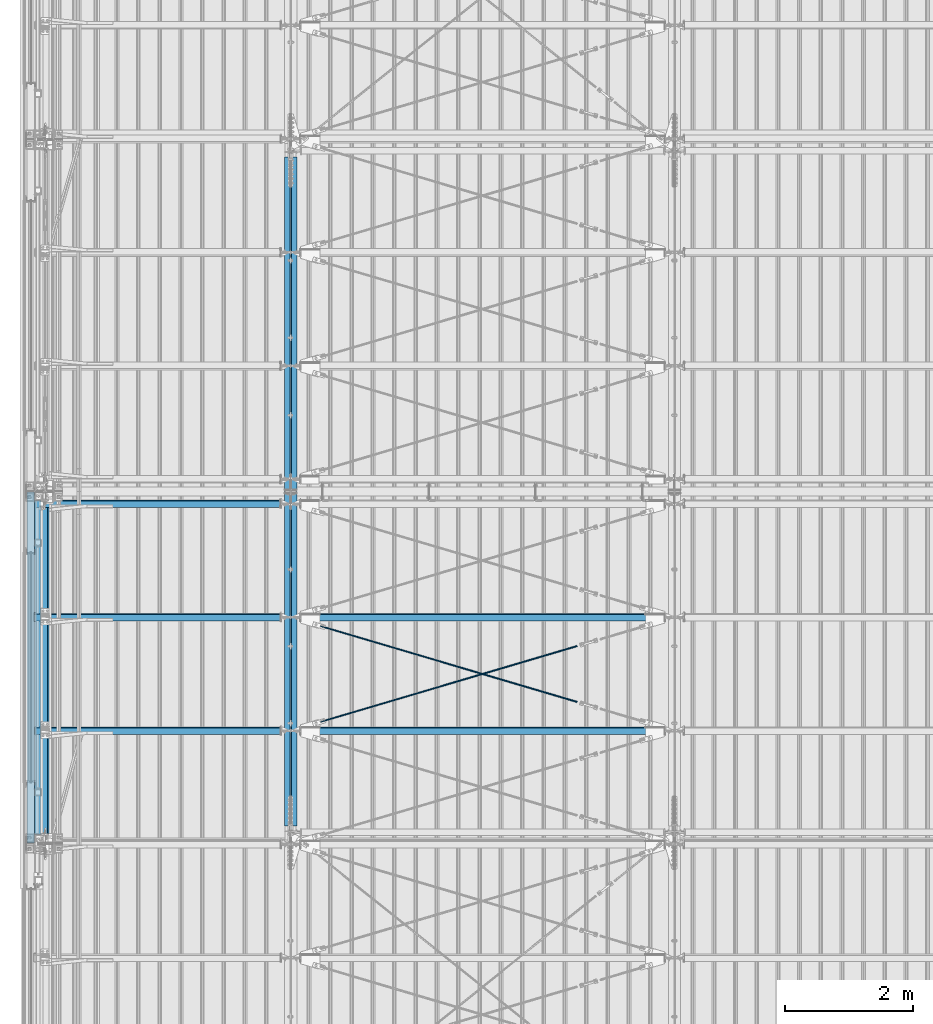
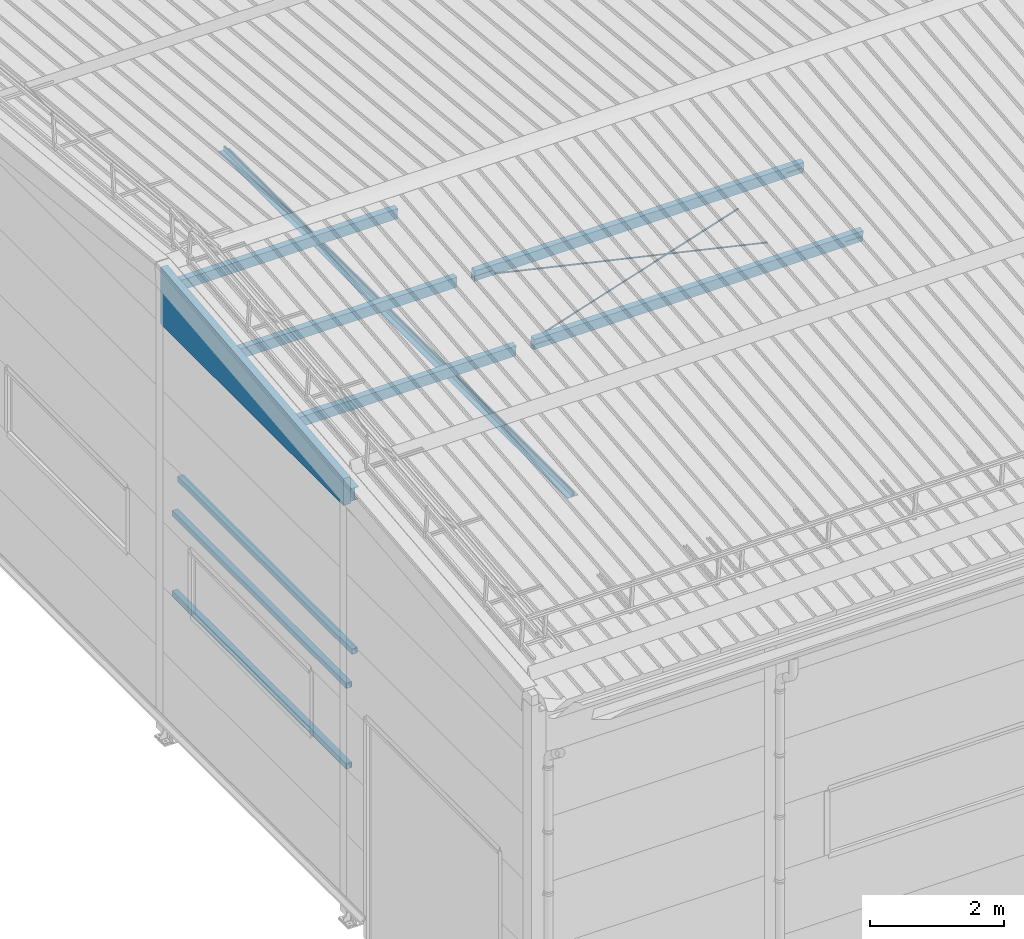
# One storey, part 245 of 709: 14 beams, 6 openings, 14 elements without a shape of their own.
"""IFC4 building model written with IfcOpenShell, lengths in millimetres."""

from ifc_helpers import new_model, si_unit, direction, frame, origin_with_axes, place, context, subcontext, project, spatial, line, indexed_curve, outline, extrude, polygons, material, element, aggregate, save


model = new_model("IFC4")

# Units and contexts
model_context = context("Model", 3, precision=0.2, world=origin_with_axes(), true_north=direction((0.0, 1.0)))
body_context = subcontext(model_context, "Body", "Model", "MODEL_VIEW")
reference_context = subcontext(model_context, "Reference", "Model", "MODEL_VIEW")
ifc_project = project(units=[si_unit("LENGTHUNIT", "METRE", prefix="MILLI"), si_unit("AREAUNIT", "SQUARE_METRE"), si_unit("VOLUMEUNIT", "CUBIC_METRE"), si_unit("MASSUNIT", "GRAM", prefix="KILO"), si_unit("TIMEUNIT", "SECOND"), si_unit("PLANEANGLEUNIT", "RADIAN"), si_unit("SOLIDANGLEUNIT", "STERADIAN"), si_unit("THERMODYNAMICTEMPERATUREUNIT", "DEGREE_CELSIUS"), si_unit("LUMINOUSINTENSITYUNIT", "LUMEN")], contexts=[model_context])

# Site, building, storey
site_placement = place(None, origin_with_axes())
site = spatial("IfcSite", under=ifc_project, at=site_placement, CompositionType="ELEMENT")
building_placement = place(site_placement, origin_with_axes())
building = spatial("IfcBuilding", under=site, at=building_placement, Name="Undefined", CompositionType="ELEMENT")
storey_placement = place(building_placement, origin_with_axes())
storey = spatial("IfcBuildingStorey", under=building, at=storey_placement, Name="Undefined", CompositionType="ELEMENT", Elevation=0.0)

# Assembly, beam
assembly_1_placement = place(storey_placement, frame((3949.0, 5673.0, 6045.00002), z_axis=(0.0, 0.0, 1.0), x_axis=(0.0, 1.0, 0.0)))
assembly_1 = element("IfcElementAssembly", 1, at=assembly_1_placement, inside=storey)
ifc_material_1 = material(Name="C345-5", Category="STEEL")
beam_1_placement = place(assembly_1_placement, origin_with_axes())
beam_1 = element("IfcBeam", 2, at=beam_1_placement, material=ifc_material_1, ObjectType="433", context=body_context, shape_type="Tessellation", body=[
    polygons([(100.0, -45.0, -45.0), (100.0, 45.0, -45.0), (10554.0, 45.0, -45.0), (10554.0, -45.0, -45.0), (100.0, 45.0, -39.0), (10554.0, 45.0, -39.0), (100.0, -39.0, -39.0), (10554.0, -39.0, -39.0), (100.0, -39.0, 45.0), (10554.0, -39.0, 45.0), (100.0, -45.0, 45.0), (10554.0, -45.0, 45.0)], [[[1, 2, 3, 4]], [[2, 5, 6, 3]], [[5, 7, 8, 6]], [[7, 9, 10, 8]], [[9, 11, 12, 10]], [[11, 1, 4, 12]], [[6, 8, 10, 12, 4, 3]], [[11, 9, 7, 5, 2, 1]]], closed=True),
])
aggregate(assembly_1, [beam_1])

assembly_2_placement = place(storey_placement, frame((4051.0, 16327.0, 6045.00002), z_axis=(0.0, 0.0, 1.0), x_axis=(0.0, -1.0, 0.0)))
assembly_2 = element("IfcElementAssembly", 3, at=assembly_2_placement, inside=storey)
beam_2_placement = place(assembly_2_placement, origin_with_axes())
beam_2 = element("IfcBeam", 4, at=beam_2_placement, material=ifc_material_1, ObjectType="434", context=body_context, shape_type="Tessellation", body=[
    polygons([(100.0, -45.0, -45.0), (100.0, 45.0, -45.0), (10554.0, 45.0, -45.0), (10554.0, -45.0, -45.0), (100.0, 45.0, -39.0), (10554.0, 45.0, -39.0), (100.0, -39.0, -39.0), (10554.0, -39.0, -39.0), (100.0, -39.0, 45.0), (10554.0, -39.0, 45.0), (100.0, -45.0, 45.0), (10554.0, -45.0, 45.0)], [[[1, 2, 3, 4]], [[2, 5, 6, 3]], [[5, 7, 8, 6]], [[7, 9, 10, 8]], [[9, 11, 12, 10]], [[11, 1, 4, 12]], [[6, 8, 10, 12, 4, 3]], [[11, 9, 7, 5, 2, 1]]], closed=True),
])
aggregate(assembly_2, [beam_2])

assembly_3_placement = place(storey_placement, frame((162.5, 5500.0, 7445.307), z_axis=(1.0, 0.0, 0.0), x_axis=(0.0, 0.9950371902, 0.099503719)))
assembly_3 = element("IfcElementAssembly", 5, at=assembly_3_placement, inside=storey)
ifc_material_2 = material(Name="C255-4", Category="STEEL")
beam_3_placement = place(assembly_3_placement, origin_with_axes())
beam_3 = element("IfcBeam", 6, at=beam_3_placement, material=ifc_material_2, ObjectType="452", context=body_context, shape_type="Tessellation", body=[
    polygons([(5323.56002, 116.0, 2.5), (5323.56002, -116.0, 2.5), (5323.56002, -116.0, 62.0), (5323.56002, -124.0, 62.0), (5323.56002, -124.0, -62.0), (5323.56002, -116.0, -62.0), (5323.56002, -116.0, -2.5), (5323.56002, 116.0, -2.5), (5323.56002, 116.0, -62.0), (5323.56002, 124.0, -62.0), (5323.56002, 124.0, 62.0), (5323.56002, 116.0, 62.0), (166.87157, 124.0, 62.0), (166.87157, 116.0, 62.0), (166.87157, 116.0, 2.5), (166.87157, -116.0, 2.5), (166.87157, -116.0, 62.0), (166.87157, -124.0, 62.0), (166.87157, -124.0, -62.0), (166.87157, -116.0, -62.0), (166.87157, -116.0, -2.5), (166.87157, 116.0, -2.5), (166.87157, 116.0, -62.0), (166.87157, 124.0, -62.0)], [[[1, 2, 3, 4, 5, 6, 7, 8, 9, 10, 11, 12]], [[12, 11, 13, 14]], [[1, 12, 14, 15]], [[2, 1, 15, 16]], [[3, 2, 16, 17]], [[4, 3, 17, 18]], [[5, 4, 18, 19]], [[6, 5, 19, 20]], [[7, 6, 20, 21]], [[8, 7, 21, 22]], [[9, 8, 22, 23]], [[10, 9, 23, 24]], [[11, 10, 24, 13]], [[23, 22, 21, 20, 19, 18, 17, 16, 15, 14, 13, 24]]], closed=True),
])
aggregate(assembly_3, [beam_3])

assembly_4_placement = place(storey_placement, frame((50.0, 11000.0, 2550.0), z_axis=(0.0, 0.0, -1.0), x_axis=(0.0, -1.0, 0.0)))
assembly_4 = element("IfcElementAssembly", 7, at=assembly_4_placement, inside=storey)
ifc_material_3 = material(Name="C355", Category="STEEL")
beam_4_placement = place(assembly_4_placement, origin_with_axes())
beam_4 = element("IfcBeam", 8, at=beam_4_placement, material=ifc_material_3, ObjectType="511", context=body_context, shape_type="Tessellation", body=[
    polygons([(142.5, -47.0, -47.0), (142.5, -47.0, 47.0), (5357.5, -47.0, 47.0), (5357.5, -47.0, -47.0), (142.5, 47.0, 47.0), (5357.5, 47.0, 47.0), (142.5, 47.0, -47.0), (5357.5, 47.0, -47.0), (142.5, -50.0, -50.0), (142.5, 50.0, -50.0), (5357.5, 50.0, -50.0), (5357.5, -50.0, -50.0), (142.5, 50.0, 50.0), (5357.5, 50.0, 50.0), (142.5, -50.0, 50.0), (5357.5, -50.0, 50.0)], [[[1, 2, 3, 4]], [[2, 5, 6, 3]], [[5, 7, 8, 6]], [[7, 1, 4, 8]], [[9, 10, 11, 12]], [[10, 13, 14, 11]], [[13, 15, 16, 14]], [[15, 9, 12, 16]], [[14, 16, 12, 11], [6, 8, 4, 3]], [[15, 13, 10, 9], [7, 5, 2, 1]]], closed=True),
])
aggregate(assembly_4, [beam_4])

assembly_5_placement = place(storey_placement, frame((50.0, 11000.0, 4020.0), z_axis=(0.0, 0.0, -1.0), x_axis=(0.0, -1.0, 0.0)))
assembly_5 = element("IfcElementAssembly", 9, at=assembly_5_placement, inside=storey)
beam_5_placement = place(assembly_5_placement, origin_with_axes())
beam_5 = element("IfcBeam", 10, at=beam_5_placement, material=ifc_material_3, ObjectType="511", context=body_context, shape_type="Tessellation", body=[
    polygons([(142.5, -47.0, -47.0), (142.5, -47.0, 47.0), (5357.5, -47.0, 47.0), (5357.5, -47.0, -47.0), (142.5, 47.0, 47.0), (5357.5, 47.0, 47.0), (142.5, 47.0, -47.0), (5357.5, 47.0, -47.0), (142.5, -50.0, -50.0), (142.5, 50.0, -50.0), (5357.5, 50.0, -50.0), (5357.5, -50.0, -50.0), (142.5, 50.0, 50.0), (5357.5, 50.0, 50.0), (142.5, -50.0, 50.0), (5357.5, -50.0, 50.0)], [[[1, 2, 3, 4]], [[2, 5, 6, 3]], [[5, 7, 8, 6]], [[7, 1, 4, 8]], [[9, 10, 11, 12]], [[10, 13, 14, 11]], [[13, 15, 16, 14]], [[15, 9, 12, 16]], [[14, 16, 12, 11], [6, 8, 4, 3]], [[15, 13, 10, 9], [7, 5, 2, 1]]], closed=True),
])
aggregate(assembly_5, [beam_5])

assembly_6_placement = place(storey_placement, frame((149.0, 11000.0, 4610.0), z_axis=(0.0, 0.0, -1.0), x_axis=(0.0, -1.0, 0.0)))
assembly_6 = element("IfcElementAssembly", 11, at=assembly_6_placement, inside=storey)
beam_6_placement = place(assembly_6_placement, origin_with_axes())
beam_6 = element("IfcBeam", 12, at=beam_6_placement, material=ifc_material_3, ObjectType="512", context=body_context, shape_type="Tessellation", body=[
    polygons([(142.5, -47.0, -47.0), (142.5, -47.0, 47.0), (5357.5, -47.0, 47.0), (5357.5, -47.0, -47.0), (142.5, 47.0, 47.0), (5357.5, 47.0, 47.0), (142.5, 47.0, -47.0), (5357.5, 47.0, -47.0), (142.5, -50.0, -50.0), (142.5, 50.0, -50.0), (5357.5, 50.0, -50.0), (5357.5, -50.0, -50.0), (142.5, 50.0, 50.0), (5357.5, 50.0, 50.0), (142.5, -50.0, 50.0), (5357.5, -50.0, 50.0)], [[[1, 2, 3, 4]], [[2, 5, 6, 3]], [[5, 7, 8, 6]], [[7, 1, 4, 8]], [[9, 10, 11, 12]], [[10, 13, 14, 11]], [[13, 15, 16, 14]], [[15, 9, 12, 16]], [[14, 16, 12, 11], [6, 8, 4, 3]], [[15, 13, 10, 9], [7, 5, 2, 1]]], closed=True),
])
aggregate(assembly_6, [beam_6])

# Assembly, beam, voiding feature
assembly_7_placement = place(storey_placement, frame((4000.0, 7262.55385, 7862.7594), z_axis=(0.2847296511, -0.9538504697, -0.095385047), x_axis=(0.9586078582, 0.2833165921, 0.028331659)))
assembly_7 = element("IfcElementAssembly", 13, at=assembly_7_placement, inside=storey)
ifc_material_4 = material(Name="C355-5", Category="STEEL")
beam_7_placement = place(assembly_7_placement, origin_with_axes())
beam_7 = element("IfcBeam", 14, at=beam_7_placement, material=ifc_material_4, ObjectType="572", context=body_context, shape_type="Tessellation", body=[
    polygons([(4849.07659, 7.36122, 4.25), (4849.07659, 6.01041, 6.01041), (4849.07659, 4.25, 7.36122), (4849.07659, 2.19996, 8.21037), (4849.07659, 0.0, 8.5), (4849.07659, -2.19996, 8.21037), (4849.07659, -4.25, 7.36122), (4849.07659, -6.01041, 6.01041), (4849.07659, -7.36121, 4.25), (4849.07659, -8.21037, 2.19996), (4849.07659, -8.5, 0.0), (4849.07659, -8.21037, -2.19996), (4849.07659, -7.36121, -4.25), (4849.07659, -6.01041, -6.01041), (4849.07659, -4.25, -7.36122), (4849.07659, -2.19996, -8.21037), (4849.07659, 0.0, -8.5), (4849.07659, 2.19996, -8.21037), (4849.07659, 4.25, -7.36122), (4849.07659, 6.01041, -6.01041), (4849.07659, 7.36122, -4.25), (4849.07659, 8.21037, -2.19996), (4849.07659, 8.5, 0.0), (4849.07659, 8.21037, 2.19996), (4669.07659, 8.21037, 2.19996), (4669.07659, 7.36122, 4.25), (4669.07659, 6.01041, 6.01041), (4669.07659, 4.25, 7.36122), (4669.07659, 2.19996, 8.21037), (4669.07659, 0.0, 8.5), (4669.07659, -2.19996, 8.21037), (4669.07659, -4.25, 7.36122), (4669.07659, -6.01041, 6.01041), (4669.07659, -7.36121, 4.25), (4669.07659, -8.21037, 2.19996), (4669.07659, -8.5, 0.0), (4669.07659, -8.21037, -2.19996), (4669.07659, -7.36121, -4.25), (4669.07659, -6.01041, -6.01041), (4669.07659, -4.25, -7.36122), (4669.07659, -2.19996, -8.21037), (4669.07659, 0.0, -8.5), (4669.07659, 2.19996, -8.21037), (4669.07659, 4.25, -7.36122), (4669.07659, 6.01041, -6.01041), (4669.07659, 7.36122, -4.25), (4669.07659, 8.21037, -2.19996), (4669.07659, 8.5, 0.0), (4669.07659, 10.0, 0.0), (4669.07659, 9.65926, 2.58819), (4669.07659, 8.66025, 5.0), (4669.07659, 7.07107, 7.07107), (4669.07659, 5.0, 8.66025), (4669.07659, 2.58819, 9.65926), (4669.07659, 0.0, 10.0), (4669.07659, -2.58819, 9.65926), (4669.07659, -5.0, 8.66025), (4669.07659, -7.07107, 7.07107), (4669.07659, -8.66025, 5.0), (4669.07659, -9.65926, 2.58819), (4669.07659, -10.0, 0.0), (4669.07659, -9.65926, -2.58819), (4669.07659, -8.66025, -5.0), (4669.07659, -7.07107, -7.07107), (4669.07659, -5.0, -8.66025), (4669.07659, -2.58819, -9.65926), (4669.07659, 0.0, -10.0), (4669.07659, 2.58819, -9.65926), (4669.07659, 5.0, -8.66025), (4669.07659, 7.07107, -7.07107), (4669.07659, 8.66025, -5.0), (4669.07659, 9.65926, -2.58819), (483.68279, 2.58819, 9.65926), (483.68279, 5.0, 8.66025), (483.68279, 7.07107, 7.07107), (483.68279, 8.66025, 5.0), (483.68279, 9.65926, 2.58819), (483.68279, 10.0, 0.0), (483.68279, 9.65926, -2.58819), (483.68279, 8.66025, -5.0), (483.68279, 7.07107, -7.07107), (483.68279, 5.0, -8.66025), (483.68279, 2.58819, -9.65926), (483.68279, 0.0, -10.0), (483.68279, -2.58819, -9.65926), (483.68279, -5.0, -8.66025), (483.68279, -7.07107, -7.07107), (483.68279, -8.66025, -5.0), (483.68279, -9.65926, -2.58819), (483.68279, -10.0, 0.0), (483.68279, -9.65926, 2.58819), (483.68279, -8.66025, 5.0), (483.68279, -7.07107, 7.07107), (483.68279, -5.0, 8.66025), (483.68279, -2.58819, 9.65926), (483.68279, 0.0, 10.0)], [[[1, 2, 3, 4, 5, 6, 7, 8, 9, 10, 11, 12, 13, 14, 15, 16, 17, 18, 19, 20, 21, 22, 23, 24]], [[24, 25, 26, 1]], [[1, 26, 27, 2]], [[2, 27, 28, 3]], [[3, 28, 29, 4]], [[4, 29, 30, 5]], [[5, 30, 31, 6]], [[6, 31, 32, 7]], [[7, 32, 33, 8]], [[8, 33, 34, 9]], [[9, 34, 35, 10]], [[10, 35, 36, 11]], [[11, 36, 37, 12]], [[12, 37, 38, 13]], [[13, 38, 39, 14]], [[14, 39, 40, 15]], [[15, 40, 41, 16]], [[16, 41, 42, 17]], [[17, 42, 43, 18]], [[18, 43, 44, 19]], [[19, 44, 45, 20]], [[20, 45, 46, 21]], [[21, 46, 47, 22]], [[22, 47, 48, 23]], [[23, 48, 25, 24]], [[49, 50, 51, 52, 53, 54, 55, 56, 57, 58, 59, 60, 61, 62, 63, 64, 65, 66, 67, 68, 69, 70, 71, 72], [47, 46, 45, 44, 43, 42, 41, 40, 39, 38, 37, 36, 35, 34, 33, 32, 31, 30, 29, 28, 27, 26, 25, 48]], [[73, 74, 75, 76, 77, 78, 79, 80, 81, 82, 83, 84, 85, 86, 87, 88, 89, 90, 91, 92, 93, 94, 95, 96]], [[79, 78, 49, 72]], [[80, 79, 72, 71]], [[81, 80, 71, 70]], [[82, 81, 70, 69]], [[83, 82, 69, 68]], [[84, 83, 68, 67]], [[85, 84, 67, 66]], [[86, 85, 66, 65]], [[87, 86, 65, 64]], [[88, 87, 64, 63]], [[89, 88, 63, 62]], [[90, 89, 62, 61]], [[91, 90, 61, 60]], [[92, 91, 60, 59]], [[93, 92, 59, 58]], [[94, 93, 58, 57]], [[95, 94, 57, 56]], [[96, 95, 56, 55]], [[73, 96, 55, 54]], [[74, 73, 54, 53]], [[75, 74, 53, 52]], [[76, 75, 52, 51]], [[77, 76, 51, 50]], [[78, 77, 50, 49]]], closed=True),
])
voiding_feature_1_placement = place(beam_7_placement, frame((4849.07659, 0.0, 0.0), z_axis=(0.0, 1.0, 0.0), x_axis=(-1.0, 0.0, 0.0)))
element("IfcVoidingFeature", 15, at=voiding_feature_1_placement, cuts=beam_7, PredefinedType="HOLE", context=reference_context, identifier="Reference", shape_type="SolidModel", body=[
    extrude(outline(indexed_curve([(10.5, 0.0), (10.14222, 2.7176), (9.09327, 5.25), (7.42462, 7.42462), (5.25, 9.09327), (2.7176, 10.14222), (0.0, 10.5), (-2.7176, 10.14222), (-5.25, 9.09327), (-7.42462, 7.42462), (-9.09327, 5.25), (-10.14222, 2.7176), (-10.5, 0.0), (-10.14222, -2.7176), (-9.09327, -5.25), (-7.42462, -7.42462), (-5.25, -9.09327), (-2.7176, -10.14222), (0.0, -10.5), (2.7176, -10.14222), (5.25, -9.09327), (7.42462, -7.42462), (9.09327, -5.25), (10.14222, -2.7176)], segments=[line(1, 2, 3, 4, 5, 6, 7, 8, 9, 10, 11, 12, 13, 14, 15, 16, 17, 18, 19, 20, 21, 22, 23, 24, 1)])), frame((0.0, 0.0, 0.0), z_axis=(-1.0, 0.0, 0.0), x_axis=(0.0, 0.0, 1.0)), (0.0, 0.0, -1.0), 180.0),
])
aggregate(assembly_7, [beam_7])

assembly_8_placement = place(storey_placement, frame((4000.0, 9035.85409, 8040.08943), z_axis=(-0.2847296511, -0.9538504697, -0.095385047), x_axis=(0.9586078582, -0.2833165921, -0.028331659)))
assembly_8 = element("IfcElementAssembly", 16, at=assembly_8_placement, inside=storey)
beam_8_placement = place(assembly_8_placement, origin_with_axes())
beam_8 = element("IfcBeam", 17, at=beam_8_placement, material=ifc_material_4, ObjectType="572", context=body_context, shape_type="Tessellation", body=[
    polygons([(4849.07659, 7.36122, 4.25), (4849.07659, 6.01041, 6.01041), (4849.07659, 4.25, 7.36122), (4849.07659, 2.19996, 8.21037), (4849.07659, 0.0, 8.5), (4849.07659, -2.19996, 8.21037), (4849.07659, -4.25, 7.36122), (4849.07659, -6.01041, 6.01041), (4849.07659, -7.36121, 4.25), (4849.07659, -8.21037, 2.19996), (4849.07659, -8.5, 0.0), (4849.07659, -8.21037, -2.19996), (4849.07659, -7.36121, -4.25), (4849.07659, -6.01041, -6.01041), (4849.07659, -4.25, -7.36122), (4849.07659, -2.19996, -8.21037), (4849.07659, 0.0, -8.5), (4849.07659, 2.19996, -8.21037), (4849.07659, 4.25, -7.36122), (4849.07659, 6.01041, -6.01041), (4849.07659, 7.36122, -4.25), (4849.07659, 8.21037, -2.19996), (4849.07659, 8.5, 0.0), (4849.07659, 8.21037, 2.19996), (4669.07659, 8.21037, 2.19996), (4669.07659, 7.36122, 4.25), (4669.07659, 6.01041, 6.01041), (4669.07659, 4.25, 7.36122), (4669.07659, 2.19996, 8.21037), (4669.07659, 0.0, 8.5), (4669.07659, -2.19996, 8.21037), (4669.07659, -4.25, 7.36122), (4669.07659, -6.01041, 6.01041), (4669.07659, -7.36121, 4.25), (4669.07659, -8.21037, 2.19996), (4669.07659, -8.5, 0.0), (4669.07659, -8.21037, -2.19996), (4669.07659, -7.36121, -4.25), (4669.07659, -6.01041, -6.01041), (4669.07659, -4.25, -7.36122), (4669.07659, -2.19996, -8.21037), (4669.07659, 0.0, -8.5), (4669.07659, 2.19996, -8.21037), (4669.07659, 4.25, -7.36122), (4669.07659, 6.01041, -6.01041), (4669.07659, 7.36122, -4.25), (4669.07659, 8.21037, -2.19996), (4669.07659, 8.5, 0.0), (4669.07659, 10.0, 0.0), (4669.07659, 9.65926, 2.58819), (4669.07659, 8.66025, 5.0), (4669.07659, 7.07107, 7.07107), (4669.07659, 5.0, 8.66025), (4669.07659, 2.58819, 9.65926), (4669.07659, 0.0, 10.0), (4669.07659, -2.58819, 9.65926), (4669.07659, -5.0, 8.66025), (4669.07659, -7.07107, 7.07107), (4669.07659, -8.66025, 5.0), (4669.07659, -9.65926, 2.58819), (4669.07659, -10.0, 0.0), (4669.07659, -9.65926, -2.58819), (4669.07659, -8.66025, -5.0), (4669.07659, -7.07107, -7.07107), (4669.07659, -5.0, -8.66025), (4669.07659, -2.58819, -9.65926), (4669.07659, 0.0, -10.0), (4669.07659, 2.58819, -9.65926), (4669.07659, 5.0, -8.66025), (4669.07659, 7.07107, -7.07107), (4669.07659, 8.66025, -5.0), (4669.07659, 9.65926, -2.58819), (483.68279, 2.58819, 9.65926), (483.68279, 5.0, 8.66025), (483.68279, 7.07107, 7.07107), (483.68279, 8.66025, 5.0), (483.68279, 9.65926, 2.58819), (483.68279, 10.0, 0.0), (483.68279, 9.65926, -2.58819), (483.68279, 8.66025, -5.0), (483.68279, 7.07107, -7.07107), (483.68279, 5.0, -8.66025), (483.68279, 2.58819, -9.65926), (483.68279, 0.0, -10.0), (483.68279, -2.58819, -9.65926), (483.68279, -5.0, -8.66025), (483.68279, -7.07107, -7.07107), (483.68279, -8.66025, -5.0), (483.68279, -9.65926, -2.58819), (483.68279, -10.0, 0.0), (483.68279, -9.65926, 2.58819), (483.68279, -8.66025, 5.0), (483.68279, -7.07107, 7.07107), (483.68279, -5.0, 8.66025), (483.68279, -2.58819, 9.65926), (483.68279, 0.0, 10.0)], [[[1, 2, 3, 4, 5, 6, 7, 8, 9, 10, 11, 12, 13, 14, 15, 16, 17, 18, 19, 20, 21, 22, 23, 24]], [[24, 25, 26, 1]], [[1, 26, 27, 2]], [[2, 27, 28, 3]], [[3, 28, 29, 4]], [[4, 29, 30, 5]], [[5, 30, 31, 6]], [[6, 31, 32, 7]], [[7, 32, 33, 8]], [[8, 33, 34, 9]], [[9, 34, 35, 10]], [[10, 35, 36, 11]], [[11, 36, 37, 12]], [[12, 37, 38, 13]], [[13, 38, 39, 14]], [[14, 39, 40, 15]], [[15, 40, 41, 16]], [[16, 41, 42, 17]], [[17, 42, 43, 18]], [[18, 43, 44, 19]], [[19, 44, 45, 20]], [[20, 45, 46, 21]], [[21, 46, 47, 22]], [[22, 47, 48, 23]], [[23, 48, 25, 24]], [[49, 50, 51, 52, 53, 54, 55, 56, 57, 58, 59, 60, 61, 62, 63, 64, 65, 66, 67, 68, 69, 70, 71, 72], [47, 46, 45, 44, 43, 42, 41, 40, 39, 38, 37, 36, 35, 34, 33, 32, 31, 30, 29, 28, 27, 26, 25, 48]], [[73, 74, 75, 76, 77, 78, 79, 80, 81, 82, 83, 84, 85, 86, 87, 88, 89, 90, 91, 92, 93, 94, 95, 96]], [[79, 78, 49, 72]], [[80, 79, 72, 71]], [[81, 80, 71, 70]], [[82, 81, 70, 69]], [[83, 82, 69, 68]], [[84, 83, 68, 67]], [[85, 84, 67, 66]], [[86, 85, 66, 65]], [[87, 86, 65, 64]], [[88, 87, 64, 63]], [[89, 88, 63, 62]], [[90, 89, 62, 61]], [[91, 90, 61, 60]], [[92, 91, 60, 59]], [[93, 92, 59, 58]], [[94, 93, 58, 57]], [[95, 94, 57, 56]], [[96, 95, 56, 55]], [[73, 96, 55, 54]], [[74, 73, 54, 53]], [[75, 74, 53, 52]], [[76, 75, 52, 51]], [[77, 76, 51, 50]], [[78, 77, 50, 49]]], closed=True),
])
voiding_feature_2_placement = place(beam_8_placement, frame((4849.07659, 0.0, 0.0), z_axis=(0.0, 1.0, 0.0), x_axis=(-1.0, 0.0, 0.0)))
element("IfcVoidingFeature", 18, at=voiding_feature_2_placement, cuts=beam_8, PredefinedType="HOLE", context=reference_context, identifier="Reference", shape_type="SolidModel", body=[
    extrude(outline(indexed_curve([(10.5, 0.0), (10.14222, 2.7176), (9.09327, 5.25), (7.42462, 7.42462), (5.25, 9.09327), (2.7176, 10.14222), (0.0, 10.5), (-2.7176, 10.14222), (-5.25, 9.09327), (-7.42462, 7.42462), (-9.09327, 5.25), (-10.14222, 2.7176), (-10.5, 0.0), (-10.14222, -2.7176), (-9.09327, -5.25), (-7.42462, -7.42462), (-5.25, -9.09327), (-2.7176, -10.14222), (0.0, -10.5), (2.7176, -10.14222), (5.25, -9.09327), (7.42462, -7.42462), (9.09327, -5.25), (10.14222, -2.7176)], segments=[line(1, 2, 3, 4, 5, 6, 7, 8, 9, 10, 11, 12, 13, 14, 15, 16, 17, 18, 19, 20, 21, 22, 23, 24, 1)])), frame((0.0, 0.0, 0.0), z_axis=(-1.0, 0.0, 0.0), x_axis=(0.0, 0.0, 1.0)), (0.0, 0.0, -1.0), 180.0),
])
aggregate(assembly_8, [beam_8])

# Assembly, beam
assembly_9_placement = place(storey_placement, frame((0.0, 7263.34988, 7854.7592), z_axis=(0.0, 0.9950371902, 0.099503719), x_axis=(1.0, 0.0, 0.0)))
assembly_9 = element("IfcElementAssembly", 19, at=assembly_9_placement, inside=storey)
beam_9_placement = place(assembly_9_placement, origin_with_axes())
beam_9 = element("IfcBeam", 20, at=beam_9_placement, material=ifc_material_3, ObjectType="563", context=body_context, shape_type="Tessellation", body=[
    polygons([(3845.0, 100.0, 50.0), (3845.0, 100.0, -50.0), (8.0, 100.0, -50.0), (8.0, 100.0, 50.0), (3845.0, -100.0, 50.0), (8.0, -100.0, 50.0), (3845.0, -100.0, -50.0), (8.0, -100.0, -50.0), (3845.0, 96.0, -46.0), (3845.0, 96.0, 46.0), (8.0, 96.0, 46.0), (8.0, 96.0, -46.0), (3845.0, -96.0, -46.0), (8.0, -96.0, -46.0), (3845.0, -96.0, 46.0), (8.0, -96.0, 46.0)], [[[1, 2, 3, 4]], [[5, 1, 4, 6]], [[7, 5, 6, 8]], [[2, 7, 8, 3]], [[1, 5, 7, 2], [10, 9, 13, 15]], [[9, 10, 11, 12]], [[13, 9, 12, 14]], [[15, 13, 14, 16]], [[10, 15, 16, 11]], [[8, 6, 4, 3], [14, 12, 11, 16]]], closed=True),
])
aggregate(assembly_9, [beam_9])

assembly_10_placement = place(storey_placement, frame((0.0, 9036.65012, 8032.08923), z_axis=(0.0, 0.9950371902, 0.099503719), x_axis=(1.0, 0.0, 0.0)))
assembly_10 = element("IfcElementAssembly", 21, at=assembly_10_placement, inside=storey)
beam_10_placement = place(assembly_10_placement, origin_with_axes())
beam_10 = element("IfcBeam", 22, at=beam_10_placement, material=ifc_material_3, ObjectType="563", context=body_context, shape_type="Tessellation", body=[
    polygons([(3845.0, 100.0, 50.0), (3845.0, 100.0, -50.0), (8.0, 100.0, -50.0), (8.0, 100.0, 50.0), (3845.0, -100.0, 50.0), (8.0, -100.0, 50.0), (3845.0, -100.0, -50.0), (8.0, -100.0, -50.0), (3845.0, 96.0, -46.0), (3845.0, 96.0, 46.0), (8.0, 96.0, 46.0), (8.0, 96.0, -46.0), (3845.0, -96.0, -46.0), (8.0, -96.0, -46.0), (3845.0, -96.0, 46.0), (8.0, -96.0, 46.0)], [[[1, 2, 3, 4]], [[5, 1, 4, 6]], [[7, 5, 6, 8]], [[2, 7, 8, 3]], [[1, 5, 7, 2], [10, 9, 13, 15]], [[9, 10, 11, 12]], [[13, 9, 12, 14]], [[15, 13, 14, 16]], [[10, 15, 16, 11]], [[8, 6, 4, 3], [14, 12, 11, 16]]], closed=True),
])
aggregate(assembly_10, [beam_10])

assembly_11_placement = place(storey_placement, frame((0.0, 10809.95037, 8209.41925), z_axis=(0.0, 0.9950371902, 0.099503719), x_axis=(1.0, 0.0, 0.0)))
assembly_11 = element("IfcElementAssembly", 23, at=assembly_11_placement, inside=storey)
beam_11_placement = place(assembly_11_placement, origin_with_axes())
beam_11 = element("IfcBeam", 24, at=beam_11_placement, material=ifc_material_3, ObjectType="564", context=body_context, shape_type="Tessellation", body=[
    polygons([(3845.0, 100.0, 50.0), (3845.0, 100.0, -50.0), (28.0, 100.0, -50.0), (28.0, 100.0, 50.0), (3845.0, -100.0, 50.0), (28.0, -100.0, 50.0), (3845.0, -100.0, -50.0), (28.0, -100.0, -50.0), (3845.0, 96.0, -46.0), (3845.0, 96.0, 46.0), (28.0, 96.0, 46.0), (28.0, 96.0, -46.0), (3845.0, -96.0, -46.0), (28.0, -96.0, -46.0), (3845.0, -96.0, 46.0), (28.0, -96.0, 46.0)], [[[1, 2, 3, 4]], [[5, 1, 4, 6]], [[7, 5, 6, 8]], [[2, 7, 8, 3]], [[1, 5, 7, 2], [10, 9, 13, 15]], [[9, 10, 11, 12]], [[13, 9, 12, 14]], [[15, 13, 14, 16]], [[10, 15, 16, 11]], [[8, 6, 4, 3], [14, 12, 11, 16]]], closed=True),
])
aggregate(assembly_11, [beam_11])

# Assembly, beam, voiding features
assembly_12_placement = place(storey_placement, frame((4000.0, 7263.34988, 7854.7991), z_axis=(0.0, 0.9950371902, 0.099503719), x_axis=(1.0, 0.0, 0.0)))
assembly_12 = element("IfcElementAssembly", 25, at=assembly_12_placement, inside=storey)
beam_12_placement = place(assembly_12_placement, origin_with_axes())
beam_12 = element("IfcBeam", 26, at=beam_12_placement, material=ifc_material_3, ObjectType="566", context=body_context, shape_type="Tessellation", body=[
    polygons([(5845.0, -5.0, 50.0), (5845.0, -5.0, 46.0), (5542.6972, -5.0, 46.0), (5542.6972, -5.0, 50.0), (5542.6972, 5.0, 46.0), (5542.6972, 5.0, 50.0), (5845.00055, 5.0, 50.0), (5845.0, 5.0, 46.0), (5845.0, -5.0, -46.0), (5845.0, -5.0, -50.0), (5542.6972, -5.0, -50.0), (5542.6972, -5.0, -46.0), (5542.6972, 5.0, -50.0), (5542.6972, 5.0, -46.0), (5845.00055, 5.0, -46.0), (5845.0, 5.0, -50.0), (155.0, 96.0, 46.0), (155.0, 96.0, -46.0), (5845.0, 96.0, -46.0), (5845.0, 96.0, 46.0), (5845.0, -96.0, 46.0), (155.0, -96.0, 46.0), (155.0, -5.0, 46.0), (457.3028, -5.0, 46.0), (457.3028, 5.0, 46.0), (155.0, 5.0, 46.0), (155.0, -96.0, -46.0), (5845.0, -96.0, -46.0), (155.0, 5.0, -46.0), (155.0, 5.0, -50.0), (457.3028, 5.0, -50.0), (457.3028, 5.0, -46.0), (457.3028, -5.0, -50.0), (457.3028, -5.0, -46.0), (155.0, -5.0, -50.0), (155.0, -5.0, -46.0), (155.0, -100.0, -50.0), (155.0, -100.0, 50.0), (155.0, -5.0, 50.0), (457.3028, -5.0, 50.0), (457.3028, 5.0, 50.0), (155.0, 5.0, 50.0), (155.0, 100.0, 50.0), (155.0, 100.0, -50.0), (5845.0, 100.0, 50.0), (5845.0, 100.0, -50.0), (5845.0, -100.0, -50.0), (5845.0, -100.0, 50.0)], [[[1, 2, 3, 4]], [[4, 3, 5, 6]], [[7, 6, 5, 8]], [[9, 10, 11, 12]], [[12, 11, 13, 14]], [[15, 14, 13, 16]], [[17, 18, 19, 20]], [[3, 2, 21, 22, 23, 24, 25, 26, 17, 20, 8, 5]], [[27, 22, 21, 28]], [[29, 30, 31, 32]], [[32, 31, 33, 34]], [[34, 33, 35, 36]], [[22, 27, 36, 35, 37, 38, 39, 23]], [[40, 24, 23, 39]], [[41, 25, 24, 40]], [[42, 26, 25, 41]], [[43, 44, 30, 29, 18, 17, 26, 42]], [[44, 43, 45, 46]], [[20, 19, 15, 16, 46, 45, 7, 8]], [[11, 10, 47, 37, 35, 33, 31, 30, 44, 46, 16, 13]], [[38, 37, 47, 48]], [[45, 43, 42, 41, 40, 39, 38, 48, 1, 4, 6, 7]], [[48, 47, 10, 9, 28, 21, 2, 1]], [[19, 18, 29, 32, 34, 36, 27, 28, 9, 12, 14, 15]]], closed=True),
])
voiding_feature_3_placement = place(beam_12_placement, frame((154.99945, 0.0, 92.98165), z_axis=(0.0, -1.0, 0.0), x_axis=(0.0, 0.0, -1.0)))
element("IfcVoidingFeature", 27, at=voiding_feature_3_placement, cuts=beam_12, Name="PLATE", PredefinedType="HOLE", context=reference_context, identifier="Reference", shape_type="SolidModel", body=[
    extrude(outline(indexed_curve([(0.0, 0.0), (185.9633, 0.0), (268.14324, 276.67769), (181.86854, 302.30336), (4.09476, 302.30336), (-82.17995, 276.67769)], segments=[line(1, 2, 3, 4, 5, 6, 1)])), frame((0.0, 0.0, 5.0), z_axis=(0.0, 0.0, 1.0), x_axis=(1.0, 0.0, 0.0)), (0.0, 0.0, -1.0), 10.0),
])
voiding_feature_4_placement = place(beam_12_placement, frame((5845.00055, 0.0, -92.98165), z_axis=(0.0, -1.0, 0.0), x_axis=(0.0, 0.0, 1.0)))
element("IfcVoidingFeature", 28, at=voiding_feature_4_placement, cuts=beam_12, Name="PLATE", PredefinedType="HOLE", context=reference_context, identifier="Reference", shape_type="SolidModel", body=[
    extrude(outline(indexed_curve([(0.0, 0.0), (185.9633, 0.0), (268.14324, 276.67769), (181.86854, 302.30336), (4.09476, 302.30336), (-82.17995, 276.67769)], segments=[line(1, 2, 3, 4, 5, 6, 1)])), frame((0.0, 0.0, 5.0), z_axis=(0.0, 0.0, 1.0), x_axis=(1.0, 0.0, 0.0)), (0.0, 0.0, -1.0), 10.0),
])
aggregate(assembly_12, [beam_12])

assembly_13_placement = place(storey_placement, frame((4000.0, 9036.65012, 8032.12913), z_axis=(0.0, 0.9950371902, 0.099503719), x_axis=(1.0, 0.0, 0.0)))
assembly_13 = element("IfcElementAssembly", 29, at=assembly_13_placement, inside=storey)
beam_13_placement = place(assembly_13_placement, origin_with_axes())
beam_13 = element("IfcBeam", 30, at=beam_13_placement, material=ifc_material_3, ObjectType="566", context=body_context, shape_type="Tessellation", body=[
    polygons([(5845.0, -5.0, 50.0), (5845.0, -5.0, 46.0), (5542.6972, -5.0, 46.0), (5542.6972, -5.0, 50.0), (5542.6972, 5.0, 46.0), (5542.6972, 5.0, 50.0), (5845.00055, 5.0, 50.0), (5845.0, 5.0, 46.0), (5845.0, -5.0, -46.0), (5845.0, -5.0, -50.0), (5542.6972, -5.0, -50.0), (5542.6972, -5.0, -46.0), (5542.6972, 5.0, -50.0), (5542.6972, 5.0, -46.0), (5845.00055, 5.0, -46.0), (5845.0, 5.0, -50.0), (155.0, 96.0, 46.0), (155.0, 96.0, -46.0), (5845.0, 96.0, -46.0), (5845.0, 96.0, 46.0), (5845.0, -96.0, 46.0), (155.0, -96.0, 46.0), (155.0, -5.0, 46.0), (457.3028, -5.0, 46.0), (457.3028, 5.0, 46.0), (155.0, 5.0, 46.0), (155.0, -96.0, -46.0), (5845.0, -96.0, -46.0), (155.0, 5.0, -46.0), (155.0, 5.0, -50.0), (457.3028, 5.0, -50.0), (457.3028, 5.0, -46.0), (457.3028, -5.0, -50.0), (457.3028, -5.0, -46.0), (155.0, -5.0, -50.0), (155.0, -5.0, -46.0), (155.0, -100.0, -50.0), (155.0, -100.0, 50.0), (155.0, -5.0, 50.0), (457.3028, -5.0, 50.0), (457.3028, 5.0, 50.0), (155.0, 5.0, 50.0), (155.0, 100.0, 50.0), (155.0, 100.0, -50.0), (5845.0, 100.0, 50.0), (5845.0, 100.0, -50.0), (5845.0, -100.0, -50.0), (5845.0, -100.0, 50.0)], [[[1, 2, 3, 4]], [[4, 3, 5, 6]], [[7, 6, 5, 8]], [[9, 10, 11, 12]], [[12, 11, 13, 14]], [[15, 14, 13, 16]], [[17, 18, 19, 20]], [[3, 2, 21, 22, 23, 24, 25, 26, 17, 20, 8, 5]], [[27, 22, 21, 28]], [[29, 30, 31, 32]], [[32, 31, 33, 34]], [[34, 33, 35, 36]], [[22, 27, 36, 35, 37, 38, 39, 23]], [[40, 24, 23, 39]], [[41, 25, 24, 40]], [[42, 26, 25, 41]], [[43, 44, 30, 29, 18, 17, 26, 42]], [[44, 43, 45, 46]], [[20, 19, 15, 16, 46, 45, 7, 8]], [[11, 10, 47, 37, 35, 33, 31, 30, 44, 46, 16, 13]], [[38, 37, 47, 48]], [[45, 43, 42, 41, 40, 39, 38, 48, 1, 4, 6, 7]], [[48, 47, 10, 9, 28, 21, 2, 1]], [[19, 18, 29, 32, 34, 36, 27, 28, 9, 12, 14, 15]]], closed=True),
])
voiding_feature_5_placement = place(beam_13_placement, frame((154.99945, 0.0, 92.98165), z_axis=(0.0, -1.0, 0.0), x_axis=(0.0, 0.0, -1.0)))
element("IfcVoidingFeature", 31, at=voiding_feature_5_placement, cuts=beam_13, Name="PLATE", PredefinedType="HOLE", context=reference_context, identifier="Reference", shape_type="SolidModel", body=[
    extrude(outline(indexed_curve([(0.0, 0.0), (185.9633, 0.0), (268.14324, 276.67769), (181.86854, 302.30336), (4.09476, 302.30336), (-82.17995, 276.67769)], segments=[line(1, 2, 3, 4, 5, 6, 1)])), frame((0.0, 0.0, 5.0), z_axis=(0.0, 0.0, 1.0), x_axis=(1.0, 0.0, 0.0)), (0.0, 0.0, -1.0), 10.0),
])
voiding_feature_6_placement = place(beam_13_placement, frame((5845.00055, 0.0, -92.98165), z_axis=(0.0, -1.0, 0.0), x_axis=(0.0, 0.0, 1.0)))
element("IfcVoidingFeature", 32, at=voiding_feature_6_placement, cuts=beam_13, Name="PLATE", PredefinedType="HOLE", context=reference_context, identifier="Reference", shape_type="SolidModel", body=[
    extrude(outline(indexed_curve([(0.0, 0.0), (185.9633, 0.0), (268.14324, 276.67769), (181.86854, 302.30336), (4.09476, 302.30336), (-82.17995, 276.67769)], segments=[line(1, 2, 3, 4, 5, 6, 1)])), frame((0.0, 0.0, 5.0), z_axis=(0.0, 0.0, 1.0), x_axis=(1.0, 0.0, 0.0)), (0.0, 0.0, -1.0), 10.0),
])
aggregate(assembly_13, [beam_13])

# Assembly, beam
assembly_14_placement = place(storey_placement, frame((-60.0, 5510.0, 8035.0), z_axis=(0.0, 0.0, -1.0), x_axis=(0.0, 1.0, 0.0)))
assembly_14 = element("IfcElementAssembly", 33, at=assembly_14_placement, inside=storey)
ifc_material_5 = material(Name="Insulation", Category="Insulation")
beam_14_placement = place(assembly_14_placement, origin_with_axes())
beam_14 = element("IfcBeam", 34, at=beam_14_placement, material=ifc_material_5, ObjectType="P-136", context=body_context, shape_type="Tessellation", body=[
    polygons([(0.0, 60.0, 595.0), (0.0, -60.0, 595.0), (5480.0, -60.0, 595.0), (5480.0, 60.0, 595.0), (5480.0, 60.0, -443.671), (0.0, 60.0, 104.329), (0.0, -60.0, 104.329), (5480.0, -60.0, -443.671)], [[[1, 2, 3, 4]], [[1, 4, 5, 6]], [[2, 1, 6, 7]], [[3, 2, 7, 8]], [[4, 3, 8, 5]], [[7, 6, 5, 8]]], closed=True),
])
aggregate(assembly_14, [beam_14])

save(model, "model.ifc")
